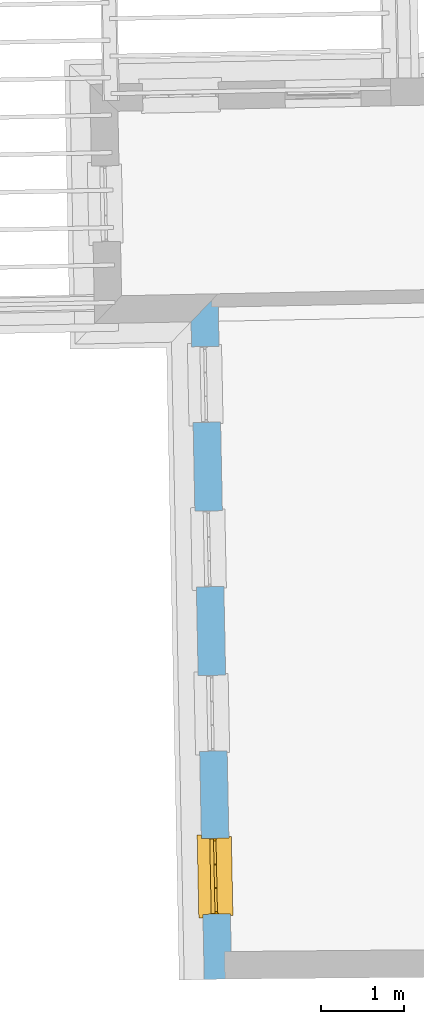
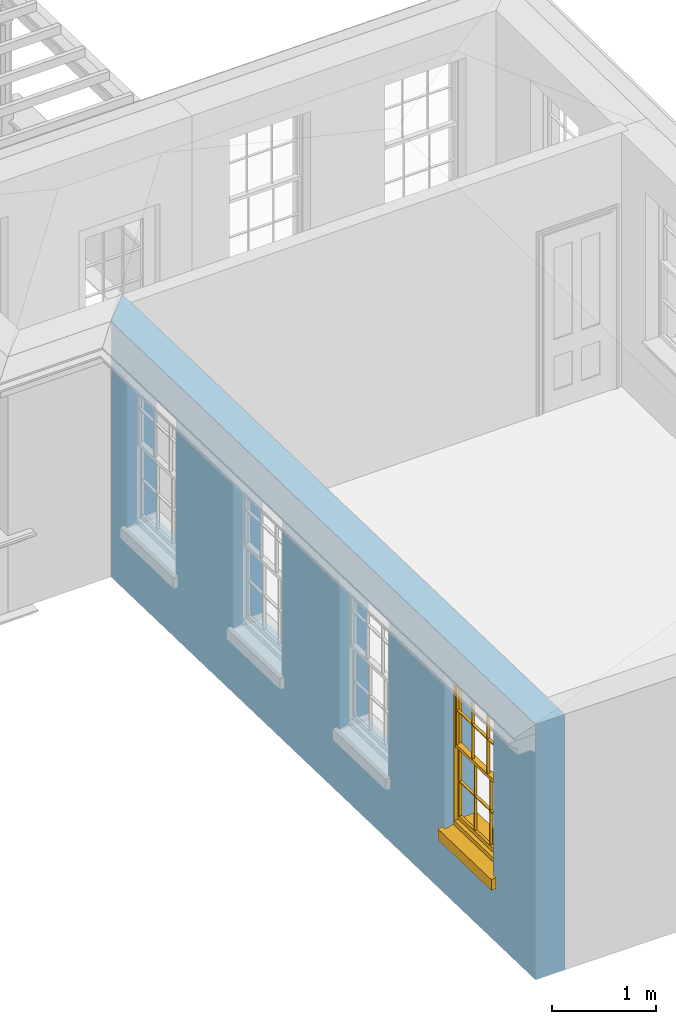
# One storey, part 3 of 11: 1 window, 4 openings, plus 1 element that does not belong to this part.
"""IFC2X3 building model written with IfcOpenShell, lengths in metres."""

from ifc_helpers import new_model, si_unit, frame, origin, place, context, subcontext, project, spatial, polyline, outline, extrude, faceted_brep, material, layer, layer_set, layer_usage, element, fill, save


model = new_model("IFC2X3")

# Units and contexts
model_context = context("Model", 3, world=origin())
body_context = subcontext(model_context, "Body", "Model", "MODEL_VIEW")
ifc_project = project(units=[si_unit("PLANEANGLEUNIT", "RADIAN"), si_unit("MASSUNIT", "GRAM", prefix="KILO"), si_unit("FORCEUNIT", "NEWTON", prefix="KILO"), si_unit("LENGTHUNIT", "METRE")], contexts=[model_context])

# Site, building, storey
site_placement = place(None, origin())
site = spatial("IfcSite", under=ifc_project, at=site_placement, CompositionType="ELEMENT")
building_placement = place(None, origin())
building = spatial("IfcBuilding", under=site, at=building_placement, Name="Building plot-11", CompositionType="ELEMENT")
storey_placement = place(None, frame((0.0, 0.0, 5.3)))
storey = spatial("IfcBuildingStorey", under=building, at=storey_placement, Name="Floor 1", CompositionType="ELEMENT", Elevation=5.3)

# Wall, openings, window
ifc_material = material(Name="Masonry")
ifc_layer = layer(ifc_material, 0.33, ventilated=False)
ifc_layer_set = layer_set([ifc_layer], Name="My Wall")
ifc_layer_usage = layer_usage(ifc_layer_set, "AXIS2", "NEGATIVE", 0.08)
wall_placement = place(storey_placement, origin())
wall = element("IfcWallStandardCase", 1, at=wall_placement, inside=storey, material=ifc_layer_usage, Name="exterior", context=body_context, shape_type="SweptSolid", body=[
    extrude(outline(polyline([(60.0013079950097, 20.3939615024824), (59.6779715062053, 20.057429906629), (59.8358519549038, 12.1620586222609), (60.1657859972327, 12.1686561757854), (60.0013079950097, 20.3939615024824)])), origin(), (0.0, 0.0, 1.0), 3.0),
])
opening_1_placement = place(storey_placement, frame((0.0, 0.0, 0.75)))
element("IfcOpeningElement", 2, at=opening_1_placement, cuts=wall, Name="Opening", ObjectType="Opening", context=body_context, shape_type="SweptSolid", body=[
    extrude(outline(polyline([(59.6839692821365, 19.7574898681482), (59.7021625357948, 18.847671751423), (60.0320965781237, 18.8542693049475), (60.0139033244655, 19.7640874216726), (59.6839692821365, 19.7574898681482)])), origin(), (0.0, 0.0, 1.0), 1.82),
])
opening_2_placement = place(storey_placement, frame((0.0, 0.0, 0.75)))
element("IfcOpeningElement", 3, at=opening_2_placement, cuts=wall, Name="Opening", ObjectType="Opening", context=body_context, shape_type="SweptSolid", body=[
    extrude(outline(polyline([(59.7234393943112, 17.7836470470562), (59.7416326479694, 16.873828930331), (60.0715666902983, 16.8804264838554), (60.0533734366401, 17.7902446005806), (59.7234393943112, 17.7836470470562)])), origin(), (0.0, 0.0, 1.0), 1.82),
])
opening_3_placement = place(storey_placement, frame((0.0, 0.0, 0.75)))
element("IfcOpeningElement", 4, at=opening_3_placement, cuts=wall, Name="Opening", ObjectType="Opening", context=body_context, shape_type="SweptSolid", body=[
    extrude(outline(polyline([(59.7629095064858, 15.8098042259642), (59.7811027601441, 14.899986109239), (60.111036802473, 14.9065836627634), (60.0928435488147, 15.8164017794886), (59.7629095064858, 15.8098042259642)])), origin(), (0.0, 0.0, 1.0), 1.82),
])
opening_4_placement = place(storey_placement, frame((0.0, 0.0, 0.75)))
opening_4 = element("IfcOpeningElement", 5, at=opening_4_placement, cuts=wall, Name="Opening", ObjectType="Opening", context=body_context, shape_type="SweptSolid", body=[
    extrude(outline(polyline([(59.8020221253779, 13.8538391232369), (59.8202153790362, 12.9440210065117), (60.1501494213651, 12.9506185600361), (60.1319561677068, 13.8604366767613), (59.8020221253779, 13.8538391232369)])), origin(), (0.0, 0.0, 1.0), 1.82),
])
window_placement = place(storey_placement, frame((60.0519721574453, 13.8588372698463, 0.75), z_axis=(0.0, 0.0, 1.0), x_axis=(0.0181932536582536, -0.909818116725164, 0.0)))
window = element("IfcWindow", 6, at=window_placement, inside=storey, Name="bedroom outside window", OverallHeight=1.82, OverallWidth=0.91, context=body_context, shape_type="Brep", held_by="IfcProductRepresentation", body=[
    faceted_brep([(0.033125, -0.105, 0.975209), (0.01, -0.105, 0.975209), (0.033125, -0.105, 1.376042), (0.876875, -0.105, 0.975209), (0.876875, -0.105, 1.376042), (0.9, -0.105, 0.975209), (0.876875, -0.105, 1.386042), (0.876875, -0.105, 1.786875), (0.9, -0.105, 1.81), (0.033125, -0.105, 1.786875), (0.033125, -0.105, 1.386042), (0.01, -0.105, 1.81), (0.876875, -0.135, 1.376042), (0.876875, -0.135, 0.975209), (0.9, -0.135, 0.937083), (0.033125, -0.135, 1.786875), (0.01, -0.135, 1.81), (0.033125, -0.135, 1.386042), (0.01, -0.135, 0.937083), (0.033125, -0.135, 0.975209), (0.033125, -0.135, 1.376042), (0.876875, -0.135, 1.786875), (0.876875, -0.135, 1.386042), (0.9, -0.135, 1.81), (0.033125, -0.105, 0.937083), (0.01, -0.105, 0.937083), (0.033125, -0.105, 0.53625), (0.876875, -0.105, 0.937083), (0.876875, -0.105, 0.53625), (0.9, -0.105, 0.937083), (0.876875, -0.105, 0.52625), (0.876875, -0.105, 0.125417), (0.9, -0.105, 0.077167), (0.033125, -0.105, 0.125417), (0.033125, -0.105, 0.52625), (0.01, -0.105, 0.077167), (-0.0425, -0.25, 0.01), (-0.0425, -0.3, 0.001667), (0.0, -0.25, 0.01), (0.9525, -0.25, 0.01), (0.91, -0.25, 0.01), (0.9525, -0.3, 0.001667), (-0.02, 0.08, 0.077167), (0.0, 0.08, 0.077167), (-0.02, 0.11, 0.077167), (0.0, -0.06, 0.077167), (0.01, -0.06, 0.077167), (0.91, -0.06, 0.077167), (0.91, 0.08, 0.077167), (0.9, -0.06, 0.077167), (0.93, 0.08, 0.077167), (0.93, 0.11, 0.077167), (0.01, -0.075, 0.975209), (0.9, -0.075, 0.975209), (0.876875, -0.075, 0.125417), (0.876875, -0.075, 0.52625), (0.9, -0.075, 0.077167), (0.876875, -0.075, 0.53625), (0.876875, -0.075, 0.937083), (0.033125, -0.075, 0.125417), (0.01, -0.075, 0.077167), (0.033125, -0.075, 0.52625), (0.033125, -0.075, 0.937083), (0.033125, -0.075, 0.53625), (-0.02, 0.08, 0.052167), (-0.02, 0.11, 0.052167), (0.93, 0.11, 0.052167), (0.93, 0.08, 0.052167), (0.91, 0.08, 0.052167), (0.0, 0.08, 0.052167), (0.91, -0.15, 0.026667), (0.0, -0.15, 0.026667), (-0.0425, -0.3, -0.123333), (0.9525, -0.3, -0.123333), (-0.0425, -0.25, -0.123333), (0.9525, -0.25, -0.123333), (0.01, -0.06, 1.81), (0.9, -0.06, 1.81), (0.0, -0.06, 1.82), (0.91, -0.06, 1.82), (0.01, -0.15, 0.077167), (0.9, -0.15, 0.077167), (0.592292, -0.105, 0.125417), (0.592292, -0.075, 0.125417), (0.317708, -0.075, 0.125417), (0.317708, -0.105, 0.125417), (0.592292, -0.105, 0.53625), (0.317708, -0.105, 0.53625), (0.317708, -0.105, 0.52625), (0.592292, -0.105, 0.52625), (0.592292, -0.075, 0.53625), (0.317708, -0.075, 0.53625), (0.592292, -0.135, 1.386042), (0.592292, -0.105, 1.386042), (0.317708, -0.105, 1.386042), (0.317708, -0.135, 1.386042), (0.317708, -0.135, 1.376042), (0.592292, -0.135, 1.376042), (0.317708, -0.105, 1.376042), (0.592292, -0.105, 1.376042), (0.602292, -0.135, 1.376042), (0.592292, -0.135, 0.975209), (0.602292, -0.135, 0.975209), (0.602292, -0.105, 0.975209), (0.592292, -0.105, 0.975209), (0.602292, -0.105, 1.376042), (0.602292, -0.075, 0.53625), (0.602292, -0.105, 0.53625), (0.317708, -0.075, 0.52625), (0.307708, -0.075, 0.125417), (0.307708, -0.075, 0.52625), (0.602292, -0.075, 0.52625), (0.602292, -0.075, 0.125417), (0.592292, -0.075, 0.52625), (0.307708, -0.075, 0.53625), (0.317708, -0.075, 0.937083), (0.307708, -0.075, 0.937083), (0.602292, -0.075, 0.937083), (0.592292, -0.075, 0.937083), (0.307708, -0.105, 0.52625), (0.307708, -0.105, 0.125417), (0.307708, -0.105, 0.53625), (0.307708, -0.105, 0.937083), (0.592292, -0.105, 0.937083), (0.317708, -0.105, 0.937083), (0.602292, -0.105, 0.937083), (0.602292, -0.105, 0.52625), (0.602292, -0.105, 0.125417), (0.307708, -0.135, 1.386042), (0.307708, -0.135, 1.376042), (0.307708, -0.135, 0.975209), (0.317708, -0.135, 0.975209), (0.317708, -0.135, 1.786875), (0.307708, -0.135, 1.786875), (0.602292, -0.135, 1.786875), (0.592292, -0.135, 1.786875), (0.602292, -0.135, 1.386042), (0.602292, -0.105, 1.386042), (0.307708, -0.105, 1.386042), (0.307708, -0.105, 1.786875), (0.317708, -0.105, 1.786875), (0.592292, -0.105, 1.786875), (0.602292, -0.105, 1.786875), (0.307708, -0.105, 1.376042), (0.317708, -0.105, 0.975209), (0.307708, -0.105, 0.975209), (0.91, -0.15, 1.82), (0.9, -0.15, 1.81), (0.01, -0.15, 1.81), (0.0, -0.15, 1.82), (0.91, -0.25, 0.0), (0.0, -0.25, 0.0), (0.91, 0.08, 0.0), (0.0, 0.08, 0.0)], [[[0, 1, 2]], [[3, 4, 5]], [[6, 7, 8]], [[9, 10, 11]], [[12, 13, 14]], [[15, 16, 17]], [[18, 19, 20]], [[21, 22, 23]], [[24, 25, 26]], [[27, 28, 29]], [[30, 31, 32]], [[33, 34, 35]], [[14, 27, 29]], [[25, 24, 18]], [[36, 37, 38]], [[39, 40, 41]], [[42, 43, 44]], [[45, 46, 43]], [[47, 48, 49]], [[50, 51, 48]], [[1, 0, 52]], [[5, 53, 3]], [[54, 55, 56]], [[57, 58, 53]], [[59, 60, 61]], [[62, 63, 52]], [[48, 43, 46, 49]], [[51, 44, 43, 48]], [[64, 42, 44, 65]], [[65, 44, 51, 66]], [[66, 51, 50, 67]], [[65, 66, 68, 69]], [[60, 56, 49, 46]], [[70, 71, 38, 40]], [[37, 41, 40, 38]], [[37, 72, 73, 41]], [[74, 75, 73, 72]], [[8, 11, 76, 77]], [[76, 78, 79, 77]], [[32, 35, 80, 81]], [[81, 80, 71, 70]], [[82, 83, 84, 85]], [[86, 87, 88, 89]], [[86, 90, 91, 87]], [[92, 93, 94, 95]], [[92, 95, 96, 97]], [[96, 98, 99, 97]], [[100, 97, 101, 102]], [[103, 104, 99, 105]], [[97, 99, 104, 101]], [[102, 103, 105, 100]], [[28, 57, 106, 107]], [[108, 84, 109, 110]], [[111, 112, 83, 113]], [[114, 110, 61, 63]], [[90, 113, 108, 91]], [[115, 91, 114, 116]], [[117, 106, 90, 118]], [[111, 106, 57, 55]], [[119, 110, 109, 120]], [[34, 61, 110, 119]], [[89, 113, 83, 82]], [[88, 108, 113, 89]], [[85, 84, 108, 88]], [[121, 114, 63, 26]], [[122, 116, 114, 121]], [[123, 118, 90, 86]], [[87, 91, 115, 124]], [[107, 106, 117, 125]], [[126, 111, 55, 30]], [[127, 112, 111, 126]], [[126, 30, 28, 107]], [[88, 119, 120, 85]], [[126, 89, 82, 127]], [[125, 123, 86, 107]], [[121, 26, 34, 119]], [[124, 122, 121, 87]], [[128, 17, 20, 129]], [[96, 129, 130, 131]], [[132, 133, 128, 95]], [[134, 135, 92, 136]], [[100, 12, 22, 136]], [[137, 6, 4, 105]], [[94, 138, 139, 140]], [[137, 93, 141, 142]], [[99, 98, 94, 93]], [[143, 2, 10, 138]], [[144, 145, 143, 98]], [[129, 143, 145, 130]], [[20, 2, 143, 129]], [[131, 144, 98, 96]], [[128, 138, 10, 17]], [[133, 139, 138, 128]], [[135, 141, 93, 92]], [[95, 94, 140, 132]], [[22, 6, 137, 136]], [[136, 137, 142, 134]], [[100, 105, 4, 12]], [[107, 86, 89, 126]], [[106, 111, 113, 90]], [[91, 108, 110, 114]], [[87, 121, 119, 88]], [[97, 100, 136, 92]], [[129, 96, 95, 128]], [[98, 143, 138, 94]], [[105, 99, 93, 137]], [[131, 101, 104, 144]], [[124, 115, 118, 123]], [[132, 140, 141, 135]], [[120, 109, 59, 33]], [[15, 9, 139, 133]], [[134, 142, 7, 21]], [[31, 54, 112, 127]], [[36, 74, 72, 37]], [[39, 41, 73, 75]], [[18, 14, 101, 131]], [[23, 16, 132, 135]], [[83, 56, 60, 84]], [[52, 53, 118, 115]], [[53, 52, 144, 104]], [[11, 8, 141, 140]], [[14, 18, 124, 123]], [[2, 1, 11, 10]], [[8, 5, 4, 6]], [[57, 53, 56, 55]], [[60, 52, 63, 61]], [[26, 25, 35, 34]], [[32, 29, 28, 30]], [[14, 23, 22, 12]], [[18, 20, 17, 16]], [[19, 0, 2, 20]], [[17, 10, 9, 15]], [[12, 4, 3, 13]], [[21, 7, 6, 22]], [[27, 58, 57, 28]], [[30, 55, 54, 31]], [[33, 59, 61, 34]], [[26, 63, 62, 24]], [[5, 8, 77, 53]], [[76, 11, 1, 52]], [[46, 45, 78, 76]], [[49, 77, 79, 47]], [[70, 146, 147, 81]], [[71, 80, 148, 149]], [[19, 130, 145, 0]], [[102, 13, 3, 103]], [[116, 122, 24, 62]], [[29, 32, 81, 14]], [[80, 35, 25, 18]], [[60, 46, 76, 52]], [[77, 49, 56, 53]], [[23, 14, 81, 147]], [[16, 148, 80, 18]], [[35, 85, 120]], [[120, 33, 35]], [[127, 82, 32]], [[32, 31, 127]], [[32, 82, 85, 35]], [[102, 101, 14]], [[14, 13, 102]], [[18, 131, 130]], [[130, 19, 18]], [[134, 21, 23]], [[23, 135, 134]], [[16, 15, 133]], [[133, 132, 16]], [[11, 140, 139]], [[139, 9, 11]], [[142, 141, 8]], [[8, 7, 142]], [[23, 147, 148, 16]], [[146, 149, 148, 147]], [[52, 115, 116]], [[116, 62, 52]], [[118, 53, 117]], [[58, 117, 53]], [[27, 125, 117, 58]], [[56, 83, 112]], [[112, 54, 56]], [[109, 84, 60]], [[60, 59, 109]], [[125, 27, 14]], [[14, 123, 125]], [[122, 124, 18]], [[18, 24, 122]], [[145, 144, 52]], [[52, 0, 145]], [[103, 3, 53]], [[53, 104, 103]], [[79, 78, 149, 146]], [[78, 45, 71, 149]], [[146, 70, 47, 79]], [[150, 75, 74, 151]], [[68, 66, 67]], [[48, 68, 67, 50]], [[69, 64, 65]], [[42, 64, 69, 43]], [[69, 68, 152, 153]], [[70, 68, 48, 47]], [[150, 152, 68, 70]], [[43, 69, 71, 45]], [[69, 153, 151, 71]], [[152, 150, 151, 153]], [[38, 151, 74, 36]], [[71, 151, 38]], [[39, 75, 150, 40]], [[40, 150, 70]]]),
])
fill(opening_4, window)

save(model, "model.ifc")
